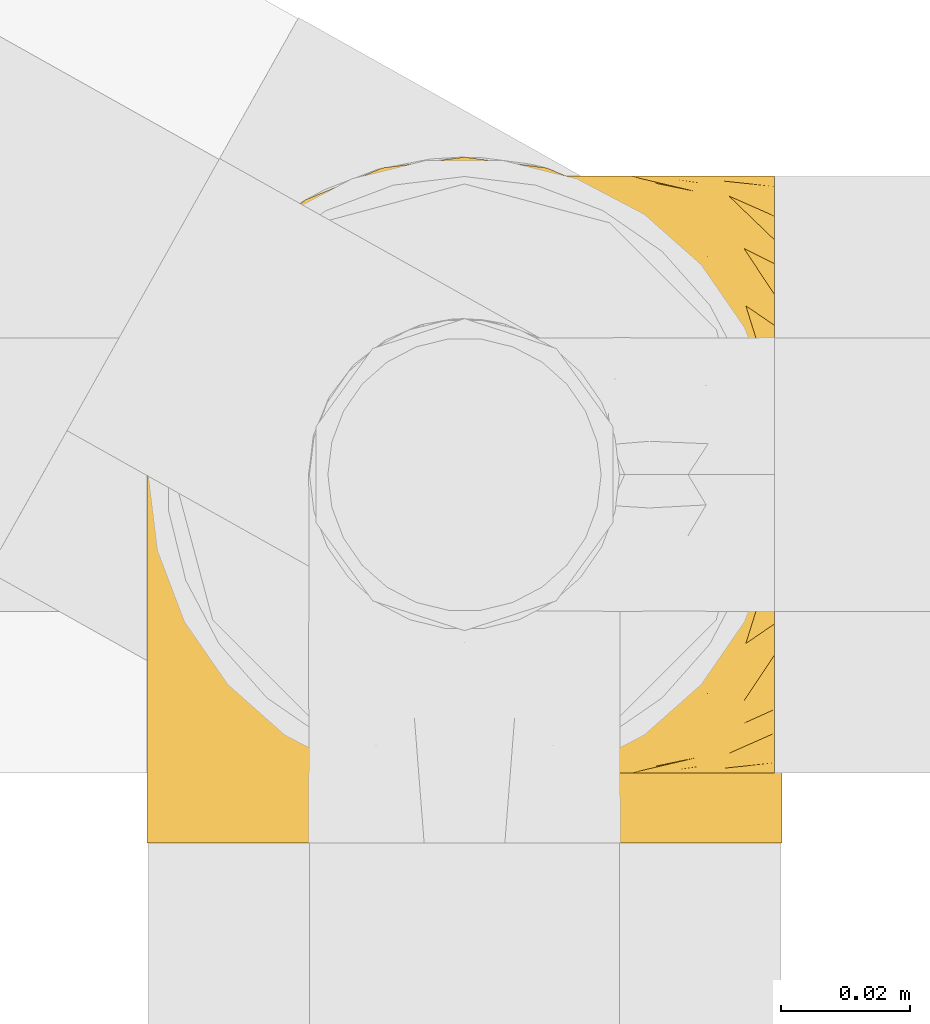
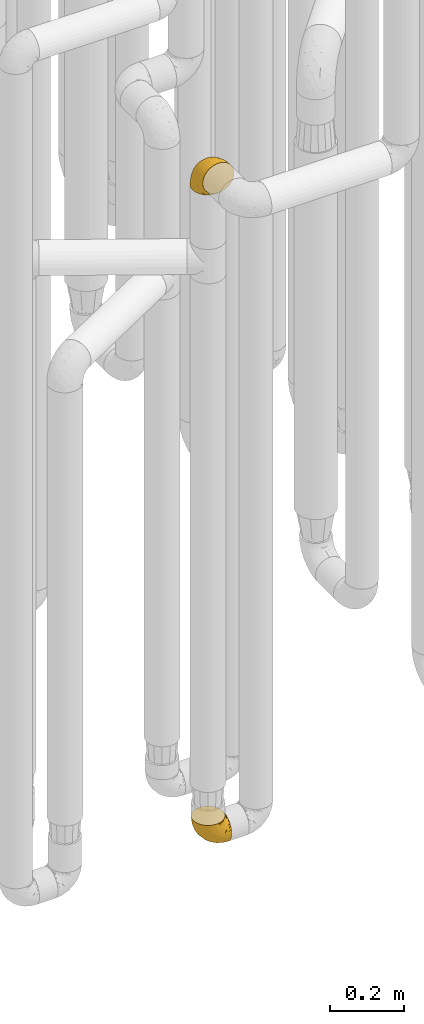
# One storey, part 152 of 827: 2 coverings.
"""IFC2X3 building model written with IfcOpenShell, lengths in millimetres."""

from ifc_helpers import new_model, entity, si_unit, converted_unit, derived_unit, direction, frame, origin, place, context, subcontext, project, spatial, faceted_brep, element, save


model = new_model("IFC2X3")

# Units and contexts
model_context = context("Model", 3, precision=0.01, world=origin(), true_north=direction((6.12303176911189e-17, 1.0)))
body_context = subcontext(model_context, "Body", "Model", "MODEL_VIEW")
ifc_project = project(units=[si_unit("LENGTHUNIT", "METRE", prefix="MILLI"), si_unit("AREAUNIT", "SQUARE_METRE"), si_unit("VOLUMEUNIT", "CUBIC_METRE"), converted_unit("PLANEANGLEUNIT", "DEGREE", entity("IfcRatioMeasure", 0.0174532925199433), si_unit("PLANEANGLEUNIT", "RADIAN"), dimensions=[0, 0, 0, 0, 0, 0, 0]), si_unit("MASSUNIT", "GRAM", prefix="KILO"), derived_unit("MASSDENSITYUNIT", [(si_unit("MASSUNIT", "GRAM", prefix="KILO"), 1), (si_unit("LENGTHUNIT", "METRE"), -3)]), derived_unit("MOMENTOFINERTIAUNIT", [(si_unit("LENGTHUNIT", "METRE"), 4)]), si_unit("TIMEUNIT", "SECOND"), si_unit("FREQUENCYUNIT", "HERTZ"), si_unit("THERMODYNAMICTEMPERATUREUNIT", "DEGREE_CELSIUS"), derived_unit("THERMALTRANSMITTANCEUNIT", [(si_unit("MASSUNIT", "GRAM", prefix="KILO"), 1), (si_unit("THERMODYNAMICTEMPERATUREUNIT", "KELVIN"), -1), (si_unit("TIMEUNIT", "SECOND"), -3)]), derived_unit("VOLUMETRICFLOWRATEUNIT", [(si_unit("LENGTHUNIT", "METRE"), 3), (si_unit("TIMEUNIT", "SECOND"), -1)]), derived_unit("MASSFLOWRATEUNIT", [(si_unit("MASSUNIT", "GRAM", prefix="KILO"), 1), (si_unit("TIMEUNIT", "SECOND"), -1)]), derived_unit("ROTATIONALFREQUENCYUNIT", [(si_unit("TIMEUNIT", "SECOND"), -1)]), si_unit("ELECTRICCURRENTUNIT", "AMPERE"), si_unit("ELECTRICVOLTAGEUNIT", "VOLT"), si_unit("POWERUNIT", "WATT"), si_unit("FORCEUNIT", "NEWTON", prefix="KILO"), si_unit("ILLUMINANCEUNIT", "LUX"), si_unit("LUMINOUSFLUXUNIT", "LUMEN"), si_unit("LUMINOUSINTENSITYUNIT", "CANDELA"), derived_unit("USERDEFINED", [(si_unit("MASSUNIT", "GRAM", prefix="KILO"), -1), (si_unit("LENGTHUNIT", "METRE"), -2), (si_unit("TIMEUNIT", "SECOND"), 3), (si_unit("LUMINOUSFLUXUNIT", "LUMEN"), 1)]), derived_unit("LINEARVELOCITYUNIT", [(si_unit("LENGTHUNIT", "METRE"), 1), (si_unit("TIMEUNIT", "SECOND"), -1)]), si_unit("PRESSUREUNIT", "PASCAL"), derived_unit("USERDEFINED", [(si_unit("LENGTHUNIT", "METRE"), -2), (si_unit("MASSUNIT", "GRAM", prefix="KILO"), 1), (si_unit("TIMEUNIT", "SECOND"), -2)]), derived_unit("LINEARFORCEUNIT", [(si_unit("MASSUNIT", "GRAM", prefix="KILO"), 1), (si_unit("LENGTHUNIT", "METRE"), 1), (si_unit("TIMEUNIT", "SECOND"), -2), (si_unit("LENGTHUNIT", "METRE"), -1)]), derived_unit("PLANARFORCEUNIT", [(si_unit("MASSUNIT", "GRAM", prefix="KILO"), 1), (si_unit("LENGTHUNIT", "METRE"), 1), (si_unit("TIMEUNIT", "SECOND"), -2), (si_unit("LENGTHUNIT", "METRE"), -2)])], contexts=[model_context])

# Site, building, storey
site_placement = place(None, origin())
site = spatial("IfcSite", under=ifc_project, at=site_placement, CompositionType="ELEMENT")
building_placement = place(site_placement, origin())
building = spatial("IfcBuilding", under=site, at=building_placement, CompositionType="ELEMENT")
storey_placement = place(building_placement, frame((0.0, 0.0, 28200.0)))
storey = spatial("IfcBuildingStorey", under=building, at=storey_placement, Name="08", CompositionType="ELEMENT", Elevation=28200.0)

# Coverings
covering_1_placement = place(storey_placement, frame((35680.25, 10308.37, 352.2)))
element("IfcCovering", 1, at=covering_1_placement, inside=storey, Name=":ADSK_", ObjectType=":ADSK_", PredefinedType="INSULATION", context=body_context, shape_type="Brep", body=[
    faceted_brep([(18.98, 83.91, 95.8), (11.67, 76.59, 95.8), (6.17, 67.83, 95.8), (2.75, 58.07, 95.8), (1.6, 47.8, 95.8), (2.75, 37.51, 95.8), (6.17, 27.74, 95.8), (11.68, 18.98, 95.8), (19.0, 11.67, 95.8), (27.76, 6.17, 95.8), (37.52, 2.75, 95.8), (47.8, 1.6, 95.8), (51.94, 2.06, 95.8), (55.01, 2.41, 95.8), (58.08, 2.75, 95.8), (62.96, 4.46, 95.8), (67.85, 6.17, 95.8), (72.23, 8.93, 95.8), (76.61, 11.68, 95.8), (80.26, 15.34, 95.8), (83.92, 19.0, 95.8), (89.42, 27.76, 95.8), (91.13, 32.64, 95.8), (92.84, 37.52, 95.8), (94.0, 47.8, 95.8), (92.84, 58.08, 95.8), (91.13, 62.96, 95.8), (89.42, 67.85, 95.8), (83.91, 76.61, 95.8), (80.25, 80.26, 95.8), (76.59, 83.92, 95.8), (72.21, 86.67, 95.8), (67.83, 89.42, 95.8), (62.95, 91.13, 95.8), (58.07, 92.84, 95.8), (55.0, 93.18, 95.8), (51.94, 93.53, 95.8), (47.8, 94.0, 95.8), (37.51, 92.84, 95.8), (27.74, 89.42, 95.8), (95.8, 47.8, 94.0), (95.8, 35.84, 92.42), (95.8, 24.7, 87.81), (95.8, 19.91, 84.13), (95.8, 15.13, 80.46), (95.8, 11.46, 75.68), (95.8, 7.78, 70.9), (95.8, 5.48, 65.32), (95.8, 3.17, 59.75), (95.8, 2.69, 56.14), (95.8, 2.42, 54.06), (95.8, 2.14, 51.97), (95.8, 1.6, 47.8), (95.8, 3.17, 35.84), (95.8, 7.78, 24.7), (95.8, 15.13, 15.13), (95.8, 24.7, 7.78), (95.8, 35.84, 3.17), (95.8, 47.8, 1.6), (95.8, 59.75, 3.17), (95.8, 70.9, 7.78), (95.8, 80.46, 15.13), (95.8, 87.81, 24.7), (95.8, 92.42, 35.84), (95.8, 94.0, 47.8), (95.8, 93.45, 51.97), (95.8, 92.9, 56.14), (95.8, 92.42, 59.75), (95.8, 90.11, 65.32), (95.8, 87.81, 70.9), (95.8, 84.13, 75.68), (95.8, 80.46, 80.46), (95.8, 75.68, 84.13), (95.8, 70.9, 87.81), (95.8, 59.75, 92.42), (60.58, 71.98, 15.84), (74.11, 63.6, 6.99), (51.59, 59.72, 14.39), (66.69, 47.8, 6.21), (76.19, 55.16, 4.26), (84.43, 47.8, 3.39), (31.2, 63.76, 31.2), (42.88, 72.22, 26.47), (79.41, 74.18, 11.44), (60.7, 92.52, 47.66), (61.85, 94.0, 61.85), (65.75, 94.0, 59.25), (69.64, 94.0, 56.65), (73.53, 94.0, 54.05), (77.43, 94.0, 51.45), (74.59, 82.14, 19.8), (54.72, 80.34, 26.22), (64.18, 87.52, 31.58), (37.94, 79.59, 38.36), (25.89, 78.25, 51.54), (34.73, 85.01, 51.6), (42.89, 90.25, 55.97), (49.83, 93.2, 62.88), (48.58, 87.23, 41.35), (22.41, 85.55, 82.24), (78.69, 93.0, 40.88), (81.64, 89.31, 29.0), (6.22, 61.31, 74.06), (12.11, 56.86, 54.53), (14.81, 68.34, 57.98), (21.61, 65.71, 43.81), (22.41, 56.99, 38.22), (30.12, 72.15, 38.33), (10.01, 70.34, 74.76), (15.36, 78.36, 76.85), (3.39, 47.8, 84.43), (19.59, 47.8, 40.43), (30.01, 47.8, 30.01), (41.19, 93.06, 78.67), (48.54, 94.0, 92.06), (49.28, 94.0, 88.32), (49.82, 94.0, 85.6), (50.37, 94.0, 82.88), (50.91, 94.0, 80.15), (51.45, 94.0, 77.43), (31.61, 89.88, 76.36), (80.15, 94.0, 50.91), (82.88, 94.0, 50.37), (85.6, 94.0, 49.82), (88.32, 94.0, 49.28), (90.19, 94.0, 48.91), (92.06, 94.0, 48.54), (6.21, 47.8, 66.69), (54.05, 94.0, 73.53), (56.65, 94.0, 69.64), (59.25, 94.0, 65.75), (24.66, 83.7, 66.13), (40.43, 47.8, 19.59), (35.17, 55.9, 24.64), (12.9, 47.8, 53.56), (53.56, 47.8, 12.9), (85.34, 81.75, 82.81), (78.44, 86.43, 81.22), (84.37, 79.8, 86.57), (89.05, 69.84, 92.75), (82.76, 79.5, 89.68), (86.31, 88.08, 72.26), (83.73, 91.6, 64.73), (77.31, 92.93, 62.45), (87.78, 92.43, 60.63), (87.91, 93.24, 56.91), (81.29, 93.36, 58.14), (93.97, 57.25, 93.7), (70.76, 89.41, 83.4), (63.67, 92.89, 75.54), (62.62, 92.66, 79.46), (90.64, 79.58, 82.28), (84.08, 86.51, 76.25), (76.28, 86.29, 84.69), (77.45, 83.91, 90.18), (88.72, 90.94, 65.12), (71.28, 91.94, 71.71), (68.09, 91.98, 75.21), (91.07, 82.79, 78.6), (57.47, 93.16, 87.27), (70.34, 88.76, 87.92), (91.35, 73.94, 86.94), (62.99, 91.89, 86.1), (94.52, 47.8, 94.52), (76.47, 92.22, 66.23), (69.96, 88.56, 91.08), (89.86, 87.72, 71.77), (78.94, 88.33, 76.21), (73.51, 92.18, 68.59), (89.62, 71.78, 89.94), (84.09, 9.09, 76.25), (86.3, 7.51, 72.26), (91.06, 12.8, 78.6), (88.32, 1.6, 49.28), (92.06, 1.6, 48.54), (82.88, 1.6, 50.37), (85.6, 1.6, 49.82), (93.97, 38.35, 93.7), (89.63, 23.84, 89.95), (50.37, 1.6, 82.88), (49.82, 1.6, 85.6), (48.54, 1.6, 92.06), (49.28, 1.6, 88.32), (82.77, 16.1, 89.68), (70.36, 6.84, 87.92), (77.31, 2.66, 62.45), (76.47, 3.37, 66.24), (69.64, 1.6, 56.65), (65.75, 1.6, 59.25), (87.78, 3.16, 60.63), (87.91, 2.35, 56.91), (89.06, 25.77, 92.76), (90.65, 16.02, 82.28), (85.35, 13.85, 82.81), (73.53, 1.6, 54.05), (77.43, 1.6, 51.45), (81.29, 2.23, 58.14), (77.46, 11.69, 90.18), (76.29, 9.31, 84.7), (57.47, 2.43, 87.25), (63.71, 2.71, 75.58), (68.11, 3.61, 75.2), (70.77, 6.18, 83.39), (71.31, 3.66, 71.7), (78.46, 9.17, 81.22), (69.52, 6.77, 90.73), (62.64, 2.93, 79.47), (91.35, 21.66, 86.94), (59.25, 1.6, 65.75), (84.6, 16.09, 86.75), (62.98, 3.7, 86.08), (51.45, 1.6, 77.43), (54.05, 1.6, 73.53), (56.65, 1.6, 69.64), (83.73, 3.99, 64.73), (80.15, 1.6, 50.91), (88.72, 4.65, 65.12), (61.85, 1.6, 61.85), (73.56, 3.43, 68.62), (78.96, 7.27, 76.22), (91.36, 9.46, 74.03), (50.91, 1.6, 80.15), (62.87, 2.4, 49.81), (76.19, 40.43, 4.26), (73.57, 13.57, 19.95), (56.07, 11.3, 30.61), (49.77, 18.65, 25.71), (44.73, 27.26, 22.43), (60.58, 23.61, 15.85), (47.64, 3.07, 60.69), (78.32, 2.69, 40.49), (51.59, 35.87, 14.39), (74.11, 31.99, 6.99), (76.04, 6.71, 29.56), (79.41, 21.41, 11.45), (14.82, 27.24, 57.98), (6.22, 34.26, 74.06), (12.12, 38.73, 54.52), (23.51, 26.97, 43.47), (31.2, 31.83, 31.2), (34.96, 23.4, 33.27), (33.86, 6.91, 64.26), (38.94, 3.4, 74.29), (30.23, 5.84, 80.41), (35.17, 39.69, 24.64), (15.85, 17.6, 73.62), (22.59, 10.38, 78.98), (21.56, 20.6, 53.69), (55.94, 5.36, 42.86), (20.67, 35.73, 41.67), (9.19, 24.84, 79.66), (25.79, 13.87, 58.41), (41.16, 9.06, 47.11), (37.95, 15.99, 38.37)], [[[0, 1, 2, 3, 4, 5, 6, 7, 8, 9, 10, 11, 12, 13, 14, 15, 16, 17, 18, 19, 20, 21, 22, 23, 24, 25, 26, 27, 28, 29, 30, 31, 32, 33, 34, 35, 36, 37, 38, 39]], [[40, 41, 42, 43, 44, 45, 46, 47, 48, 49, 50, 51, 52, 53, 54, 55, 56, 57, 58, 59, 60, 61, 62, 63, 64, 65, 66, 67, 68, 69, 70, 71, 72, 73, 74]], [[75, 76, 77]], [[78, 79, 80]], [[77, 81, 82]], [[76, 75, 83]], [[84, 85, 86, 87, 88, 89]], [[90, 91, 92]], [[76, 60, 59]], [[93, 94, 95]], [[90, 62, 61]], [[83, 61, 60]], [[96, 97, 84]], [[98, 93, 95]], [[0, 39, 99]], [[100, 84, 89]], [[62, 101, 63]], [[2, 102, 3]], [[92, 84, 100]], [[103, 102, 104]], [[103, 105, 106]], [[93, 107, 94]], [[1, 108, 2]], [[92, 101, 90]], [[108, 1, 109]], [[102, 110, 3]], [[93, 82, 107]], [[102, 108, 104]], [[111, 106, 112]], [[109, 0, 99]], [[113, 37, 114, 115, 116, 117, 118, 119]], [[120, 38, 113]], [[100, 89, 121, 122, 123, 124, 125, 126, 64]], [[127, 102, 103]], [[97, 119, 128, 129, 130, 85]], [[99, 120, 131]], [[132, 133, 77]], [[59, 80, 79]], [[1, 0, 109]], [[98, 84, 92]], [[94, 109, 131]], [[120, 39, 38]], [[93, 91, 82]], [[104, 94, 105]], [[97, 113, 119]], [[95, 120, 96]], [[83, 90, 61]], [[91, 93, 98]], [[64, 63, 100]], [[100, 63, 101]], [[77, 76, 79]], [[133, 106, 81]], [[84, 97, 85]], [[113, 96, 120]], [[113, 97, 96]], [[37, 113, 38]], [[110, 102, 127]], [[110, 4, 3]], [[103, 111, 134, 127]], [[90, 75, 91]], [[82, 81, 107]], [[91, 75, 82]], [[77, 82, 75]], [[76, 83, 60]], [[90, 83, 75]], [[105, 107, 81]], [[94, 131, 95]], [[105, 94, 107]], [[109, 94, 104]], [[120, 95, 131]], [[98, 95, 96]], [[84, 98, 96]], [[98, 92, 91]], [[106, 105, 81]], [[103, 104, 105]], [[112, 106, 133]], [[103, 106, 111]], [[112, 133, 132]], [[81, 77, 133]], [[77, 78, 135, 132]], [[120, 99, 39]], [[109, 99, 131]], [[59, 58, 80]], [[59, 79, 76]], [[90, 101, 62]], [[100, 101, 92]], [[2, 108, 102]], [[109, 104, 108]], [[78, 77, 79]], [[136, 137, 138]], [[27, 139, 140]], [[141, 142, 143]], [[144, 145, 121]], [[146, 89, 88]], [[147, 139, 25]], [[148, 149, 150]], [[136, 151, 152]], [[147, 40, 74]], [[24, 147, 25]], [[140, 153, 154]], [[33, 116, 34]], [[73, 72, 151]], [[114, 37, 36, 35, 34, 116, 115]], [[146, 155, 144]], [[156, 85, 130]], [[157, 149, 148]], [[151, 158, 152]], [[117, 33, 159]], [[29, 154, 160]], [[161, 74, 73]], [[162, 128, 119]], [[66, 65, 64, 126, 125, 124, 123, 122, 67]], [[163, 147, 24]], [[27, 140, 28]], [[149, 129, 150]], [[139, 27, 26, 25]], [[68, 144, 69]], [[129, 128, 150]], [[164, 87, 86]], [[130, 129, 149]], [[122, 145, 67]], [[154, 153, 148]], [[162, 119, 159]], [[165, 30, 160]], [[150, 160, 148]], [[128, 162, 150]], [[30, 165, 31]], [[145, 144, 68]], [[89, 146, 144]], [[87, 164, 143]], [[166, 155, 142]], [[88, 87, 143]], [[162, 160, 150]], [[160, 30, 29]], [[154, 29, 28]], [[140, 154, 28]], [[160, 154, 148]], [[140, 137, 153]], [[157, 148, 153]], [[156, 130, 157]], [[153, 137, 157]], [[157, 137, 156]], [[167, 137, 136]], [[168, 85, 156]], [[152, 168, 167]], [[167, 168, 156]], [[164, 152, 141]], [[71, 158, 72]], [[152, 167, 136]], [[88, 142, 146]], [[144, 155, 69]], [[146, 142, 155]], [[70, 166, 71]], [[142, 141, 166]], [[70, 69, 155]], [[141, 158, 71]], [[161, 73, 151]], [[138, 137, 140]], [[161, 136, 169]], [[136, 161, 151]], [[74, 161, 169]], [[152, 158, 141]], [[151, 72, 158]], [[168, 152, 164]], [[137, 167, 156]], [[164, 86, 168]], [[85, 168, 86]], [[116, 33, 117]], [[130, 149, 157]], [[67, 145, 68]], [[121, 89, 144]], [[145, 122, 121]], [[40, 147, 163]], [[169, 147, 74]], [[159, 33, 32]], [[162, 159, 32]], [[159, 119, 118, 117]], [[139, 147, 169]], [[139, 169, 138]], [[162, 32, 31]], [[141, 143, 164]], [[88, 143, 142]], [[71, 166, 141]], [[155, 166, 70]], [[139, 138, 140]], [[169, 136, 138]], [[160, 162, 165]], [[162, 31, 165]], [[170, 171, 172]], [[173, 174, 52, 51, 50, 49, 48, 175, 176]], [[177, 178, 41]], [[179, 15, 180]], [[12, 11, 181, 182, 180, 14, 13]], [[183, 21, 20]], [[19, 18, 184]], [[185, 186, 187]], [[186, 188, 187]], [[43, 172, 44]], [[189, 190, 47]], [[23, 22, 21, 191]], [[170, 192, 193]], [[40, 163, 177]], [[194, 195, 196]], [[24, 23, 177]], [[197, 198, 183]], [[199, 15, 179]], [[47, 46, 189]], [[200, 201, 202]], [[201, 203, 204]], [[205, 206, 184]], [[207, 41, 178]], [[16, 15, 199]], [[14, 180, 15]], [[202, 201, 198]], [[208, 201, 200]], [[163, 24, 177]], [[48, 47, 190]], [[196, 195, 189]], [[197, 184, 202]], [[204, 193, 209]], [[210, 211, 212]], [[206, 212, 213]], [[205, 17, 210]], [[184, 206, 202]], [[210, 212, 206]], [[185, 194, 214]], [[189, 215, 190]], [[216, 45, 214]], [[186, 171, 170]], [[189, 216, 196]], [[197, 20, 19]], [[194, 185, 187]], [[197, 183, 20]], [[184, 197, 19]], [[197, 202, 198]], [[206, 200, 202]], [[204, 183, 198]], [[201, 208, 203]], [[203, 208, 217]], [[204, 198, 201]], [[217, 188, 218]], [[193, 219, 170]], [[171, 186, 185]], [[170, 218, 186]], [[170, 219, 218]], [[42, 207, 192]], [[171, 220, 172]], [[216, 189, 46]], [[214, 194, 196]], [[44, 220, 45]], [[214, 196, 216]], [[216, 46, 45]], [[214, 45, 220]], [[192, 43, 42]], [[204, 203, 219]], [[207, 193, 192]], [[209, 193, 178]], [[41, 207, 42]], [[193, 207, 178]], [[43, 192, 172]], [[170, 172, 192]], [[204, 219, 193]], [[219, 203, 218]], [[217, 218, 203]], [[188, 186, 218]], [[206, 213, 200]], [[208, 200, 213]], [[199, 210, 16]], [[215, 189, 195]], [[215, 175, 190]], [[175, 48, 190]], [[199, 179, 221, 211]], [[210, 199, 211]], [[23, 191, 177]], [[40, 177, 41]], [[178, 177, 191]], [[21, 183, 191]], [[209, 191, 183]], [[205, 18, 17]], [[17, 16, 210]], [[171, 185, 214]], [[172, 220, 44]], [[214, 220, 171]], [[191, 209, 178]], [[204, 209, 183]], [[206, 205, 210]], [[18, 205, 184]], [[222, 195, 194, 187, 188, 217]], [[57, 223, 80]], [[224, 225, 226]], [[226, 227, 228]], [[229, 217, 208, 213, 212, 211]], [[230, 52, 174, 173, 176, 175, 215, 195]], [[231, 232, 228]], [[231, 78, 223]], [[223, 57, 232]], [[224, 233, 225]], [[233, 54, 53]], [[234, 232, 56]], [[56, 55, 234]], [[234, 224, 228]], [[235, 236, 237]], [[224, 55, 54]], [[238, 239, 240]], [[52, 230, 53]], [[241, 242, 243]], [[227, 244, 231]], [[11, 10, 242]], [[236, 6, 5]], [[7, 245, 8]], [[8, 246, 9]], [[238, 247, 235]], [[222, 229, 248]], [[242, 211, 221, 179, 180, 182, 181, 11]], [[233, 53, 230]], [[111, 112, 249]], [[250, 6, 236]], [[246, 251, 241]], [[6, 250, 7]], [[127, 236, 110]], [[248, 229, 252]], [[246, 8, 245]], [[235, 245, 250]], [[236, 5, 110]], [[235, 249, 238]], [[237, 236, 127]], [[243, 9, 246]], [[252, 229, 241]], [[56, 232, 57]], [[222, 230, 195]], [[225, 248, 252]], [[248, 233, 230]], [[54, 233, 224]], [[231, 228, 227]], [[244, 132, 231]], [[248, 225, 233]], [[226, 225, 253]], [[235, 250, 236]], [[245, 7, 250]], [[251, 246, 245]], [[243, 246, 241]], [[247, 245, 235]], [[252, 251, 253]], [[229, 222, 217]], [[230, 222, 248]], [[5, 4, 110]], [[237, 127, 134, 111]], [[238, 249, 239]], [[224, 234, 55]], [[232, 234, 228]], [[242, 241, 229]], [[10, 9, 243]], [[211, 242, 229]], [[10, 243, 242]], [[80, 223, 78]], [[80, 58, 57]], [[231, 223, 232]], [[227, 240, 239]], [[224, 226, 228]], [[240, 226, 253]], [[227, 239, 244]], [[226, 240, 227]], [[251, 247, 253]], [[240, 253, 247]], [[249, 235, 237]], [[237, 111, 249]], [[112, 132, 244]], [[112, 244, 249]], [[78, 231, 132, 135]], [[249, 244, 239]], [[247, 238, 240]], [[245, 247, 251]], [[251, 252, 241]], [[225, 252, 253]]]),
])
covering_2_placement = place(storey_placement, frame((35677.3, 10297.57, 2541.4)))
element("IfcCovering", 2, at=covering_2_placement, inside=storey, Name=":ADSK_", ObjectType=":ADSK_", PredefinedType="INSULATION", context=body_context, shape_type="Brep", body=[
    faceted_brep([(99.9, 1.6, 58.6), (98.66, 1.6, 69.54), (95.02, 1.6, 79.93), (89.17, 1.6, 89.25), (81.38, 1.6, 97.03), (72.06, 1.6, 102.88), (61.68, 1.6, 106.51), (50.75, 1.6, 107.75), (39.8, 1.6, 106.51), (29.41, 1.6, 102.87), (20.09, 1.6, 97.02), (12.31, 1.6, 89.23), (6.46, 1.6, 79.91), (2.83, 1.6, 69.53), (1.6, 1.6, 58.6), (2.24, 1.6, 52.89), (2.83, 1.6, 47.65), (4.65, 1.6, 42.46), (6.47, 1.6, 37.26), (12.32, 1.6, 27.94), (20.11, 1.6, 20.16), (29.43, 1.6, 14.31), (39.81, 1.6, 10.68), (50.75, 1.6, 9.45), (61.69, 1.6, 10.68), (72.08, 1.6, 14.32), (81.4, 1.6, 20.17), (89.18, 1.6, 27.96), (95.03, 1.6, 37.28), (96.85, 1.6, 42.47), (98.66, 1.6, 47.66), (99.25, 1.6, 52.89), (99.57, 1.6, 55.75), (38.02, 11.12, 1.6), (26.17, 16.03, 1.6), (21.08, 19.94, 1.6), (15.99, 23.84, 1.6), (12.09, 28.93, 1.6), (8.18, 34.02, 1.6), (5.73, 39.95, 1.6), (3.27, 45.87, 1.6), (2.35, 52.86, 1.6), (1.97, 55.73, 1.6), (1.6, 58.6, 1.6), (3.27, 71.32, 1.6), (8.18, 83.17, 1.6), (15.99, 93.35, 1.6), (26.17, 101.16, 1.6), (38.02, 106.07, 1.6), (50.75, 107.75, 1.6), (63.47, 106.07, 1.6), (75.32, 101.16, 1.6), (85.5, 93.35, 1.6), (93.31, 83.17, 1.6), (98.22, 71.32, 1.6), (99.9, 58.6, 1.6), (99.14, 52.86, 1.6), (98.22, 45.87, 1.6), (95.77, 39.95, 1.6), (93.31, 34.02, 1.6), (89.4, 28.93, 1.6), (85.5, 23.84, 1.6), (80.41, 19.94, 1.6), (75.32, 16.03, 1.6), (63.47, 11.12, 1.6), (50.75, 9.45, 1.6), (59.31, 81.82, 69.96), (73.08, 84.02, 59.59), (63.72, 93.05, 51.96), (50.75, 102.55, 34.4), (58.64, 104.83, 23.37), (50.75, 105.83, 13.68), (76.74, 91.87, 41.52), (67.68, 101.74, 26.26), (78.92, 97.07, 20.18), (94.31, 38.45, 72.33), (98.76, 22.17, 65.88), (98.4, 42.04, 57.55), (94.57, 77.69, 23.76), (89.91, 75.76, 46.5), (96.32, 62.11, 46.57), (98.79, 66.08, 21.17), (99.9, 54.26, 23.41), (99.9, 55.35, 17.92), (99.9, 56.44, 12.43), (99.9, 56.98, 9.72), (99.9, 57.52, 7.01), (87.31, 87.84, 26.77), (95.61, 19.41, 76.59), (60.43, 48.89, 95.55), (65.24, 26.34, 102.57), (72.87, 44.55, 92.89), (99.9, 23.41, 54.26), (99.9, 28.03, 51.17), (99.9, 32.65, 48.08), (99.9, 37.28, 44.99), (99.9, 41.9, 41.9), (90.65, 20.6, 85.16), (63.14, 63.36, 85.97), (91.89, 62.21, 59.58), (75.25, 19.94, 99.5), (50.75, 13.68, 105.83), (82.18, 80.85, 53.59), (85.08, 66.53, 67.0), (76.93, 71.06, 71.56), (50.75, 63.99, 87.47), (50.75, 75.73, 75.73), (83.02, 26.77, 92.24), (99.9, 4.31, 58.06), (99.9, 7.01, 57.52), (99.9, 12.43, 56.44), (99.9, 17.92, 55.35), (87.13, 43.43, 81.33), (80.85, 56.23, 80.35), (99.17, 54.97, 39.44), (50.75, 34.4, 102.55), (99.9, 44.99, 37.28), (99.9, 48.08, 32.65), (99.9, 51.17, 28.03), (50.75, 87.47, 63.99), (67.61, 74.55, 74.55), (72.25, 60.86, 83.62), (50.75, 49.19, 95.01), (50.75, 95.01, 49.19), (98.69, 10.27, 46.96), (99.01, 48.79, 8.77), (98.79, 45.16, 18.28), (98.29, 44.99, 11.68), (68.51, 6.17, 11.79), (76.82, 7.65, 15.69), (98.54, 21.59, 42.49), (99.3, 19.96, 47.41), (83.57, 21.0, 7.94), (89.47, 27.2, 9.27), (75.76, 14.83, 7.98), (84.86, 19.7, 13.4), (75.89, 10.93, 13.04), (64.77, 9.63, 7.36), (90.83, 19.97, 23.46), (94.62, 21.13, 30.46), (90.37, 14.14, 26.54), (91.18, 30.2, 6.76), (88.65, 8.12, 26.46), (84.11, 9.93, 20.77), (91.75, 24.62, 20.68), (96.86, 11.87, 40.26), (50.75, 7.15, 7.15), (58.97, 5.32, 9.28), (98.37, 26.68, 38.78), (83.91, 13.92, 18.27), (97.52, 30.67, 31.78), (95.55, 36.65, 12.75), (98.76, 42.89, 22.96), (95.26, 34.04, 17.55), (98.04, 36.6, 27.63), (90.65, 26.41, 15.23), (93.51, 10.07, 33.25), (94.16, 15.83, 32.43), (99.1, 41.99, 27.9), (25.73, 14.83, 7.97), (10.84, 26.4, 15.22), (17.92, 21.01, 7.93), (16.64, 19.71, 13.38), (30.44, 5.72, 13.12), (2.95, 21.6, 42.49), (2.19, 19.96, 47.4), (1.6, 28.03, 51.17), (4.63, 11.87, 40.24), (17.39, 9.93, 20.76), (1.6, 56.44, 12.43), (1.6, 57.52, 7.01), (1.6, 58.06, 4.31), (12.86, 8.13, 26.44), (11.13, 14.15, 26.52), (3.2, 44.99, 11.68), (5.94, 36.65, 12.75), (12.02, 27.21, 9.27), (6.23, 34.04, 17.55), (10.31, 30.2, 6.76), (8.0, 10.06, 33.21), (7.34, 15.83, 32.41), (2.48, 48.79, 8.77), (2.73, 42.89, 22.96), (2.64, 45.38, 18.48), (1.6, 12.43, 56.44), (2.8, 10.28, 46.95), (36.71, 9.64, 7.36), (1.6, 55.35, 17.92), (1.6, 54.26, 23.41), (38.59, 6.05, 9.85), (1.6, 7.01, 57.52), (1.6, 9.72, 56.98), (1.6, 32.65, 48.08), (3.12, 26.68, 38.78), (17.59, 13.92, 18.25), (1.6, 37.28, 44.99), (3.98, 30.66, 31.74), (6.87, 21.14, 30.45), (3.45, 36.59, 27.63), (9.76, 24.6, 20.65), (1.6, 17.92, 55.35), (1.6, 23.41, 54.26), (25.62, 10.93, 13.03), (10.67, 19.97, 23.44), (2.39, 41.99, 27.9), (1.6, 48.08, 32.65), (1.6, 51.17, 28.03), (1.6, 44.99, 37.28), (1.6, 41.9, 41.9), (2.4, 55.26, 39.74), (42.85, 104.83, 23.37), (14.18, 87.84, 26.77), (11.56, 75.91, 46.18), (19.27, 80.84, 53.54), (24.75, 91.87, 41.53), (28.37, 83.98, 59.61), (5.95, 19.16, 76.79), (2.79, 22.37, 66.11), (2.71, 66.08, 21.17), (37.78, 93.05, 51.96), (33.81, 101.74, 26.26), (22.57, 97.07, 20.18), (6.92, 77.69, 23.76), (28.61, 44.55, 92.88), (36.24, 26.34, 102.57), (41.05, 48.9, 95.54), (24.55, 70.99, 71.63), (33.88, 74.55, 74.55), (7.11, 37.8, 72.51), (42.18, 81.82, 69.96), (18.46, 26.77, 92.23), (10.84, 20.6, 85.15), (20.69, 56.15, 80.45), (29.27, 60.85, 83.65), (3.1, 42.06, 57.57), (9.18, 57.03, 63.68), (38.38, 63.4, 85.95), (26.23, 19.94, 99.49), (14.34, 43.59, 81.23), (5.46, 62.61, 47.07), (16.39, 66.52, 66.99)], [[[0, 1, 2, 3, 4, 5, 6, 7, 8, 9, 10, 11, 12, 13, 14, 15, 16, 17, 18, 19, 20, 21, 22, 23, 24, 25, 26, 27, 28, 29, 30, 31, 32]], [[33, 34, 35, 36, 37, 38, 39, 40, 41, 42, 43, 44, 45, 46, 47, 48, 49, 50, 51, 52, 53, 54, 55, 56, 57, 58, 59, 60, 61, 62, 63, 64, 65]], [[66, 67, 68]], [[69, 70, 71]], [[68, 72, 73]], [[73, 72, 74]], [[75, 76, 77]], [[78, 79, 80]], [[51, 50, 73]], [[81, 82, 83, 84, 85, 86, 55]], [[52, 87, 53]], [[74, 52, 51]], [[2, 1, 88]], [[89, 90, 91]], [[77, 92, 93, 94, 95, 96]], [[55, 54, 81]], [[78, 53, 87]], [[5, 90, 6]], [[88, 76, 75]], [[97, 3, 2]], [[89, 91, 98]], [[99, 80, 79]], [[90, 5, 100]], [[74, 87, 52]], [[100, 5, 4]], [[90, 101, 6]], [[79, 102, 103]], [[102, 67, 104]], [[105, 98, 106]], [[107, 4, 3]], [[76, 0, 108, 109, 110, 111, 92]], [[107, 112, 113]], [[114, 77, 96]], [[89, 115, 90]], [[114, 96, 116, 117, 118, 82]], [[75, 97, 88]], [[119, 66, 68]], [[50, 71, 70]], [[100, 91, 90]], [[99, 77, 80]], [[102, 104, 103]], [[97, 107, 3]], [[80, 81, 78]], [[107, 97, 112]], [[68, 73, 70]], [[66, 98, 120]], [[78, 81, 54]], [[114, 81, 80]], [[53, 78, 54]], [[78, 87, 79]], [[102, 87, 72]], [[79, 103, 99]], [[4, 107, 100]], [[91, 100, 107]], [[88, 97, 2]], [[112, 97, 75]], [[99, 112, 75]], [[103, 104, 113]], [[91, 121, 98]], [[89, 105, 122, 115]], [[101, 90, 115]], [[101, 7, 6]], [[88, 1, 76]], [[0, 76, 1]], [[92, 77, 76]], [[73, 74, 51]], [[87, 74, 72]], [[81, 114, 82]], [[77, 114, 80]], [[87, 102, 79]], [[67, 102, 72]], [[68, 67, 72]], [[67, 120, 104]], [[120, 121, 104]], [[104, 121, 113]], [[121, 120, 98]], [[91, 107, 113]], [[91, 113, 121]], [[103, 113, 112]], [[106, 98, 66]], [[105, 89, 98]], [[106, 66, 119]], [[67, 66, 120]], [[68, 69, 123, 119]], [[50, 49, 71]], [[50, 70, 73]], [[112, 99, 103]], [[77, 99, 75]], [[69, 68, 70]], [[29, 124, 110]], [[84, 83, 125]], [[126, 82, 118]], [[59, 58, 127]], [[25, 128, 129]], [[130, 93, 131]], [[132, 62, 133]], [[134, 135, 136]], [[137, 65, 64]], [[64, 134, 137]], [[138, 139, 140]], [[111, 110, 124, 92]], [[134, 136, 137]], [[134, 64, 63]], [[141, 61, 60]], [[125, 58, 57]], [[142, 143, 140]], [[142, 26, 143]], [[127, 83, 82]], [[28, 124, 29]], [[108, 0, 32, 31, 30, 110, 109]], [[30, 29, 110]], [[135, 144, 138]], [[28, 145, 124]], [[57, 56, 55, 86, 85, 84]], [[146, 147, 23]], [[24, 23, 147]], [[25, 143, 26]], [[95, 94, 148]], [[24, 128, 25]], [[149, 138, 143]], [[124, 145, 131]], [[127, 58, 125]], [[150, 148, 139]], [[127, 126, 151]], [[151, 59, 127]], [[152, 151, 126]], [[153, 154, 155]], [[153, 133, 141]], [[145, 28, 27]], [[142, 156, 27]], [[157, 148, 130]], [[61, 133, 62]], [[134, 132, 135]], [[147, 128, 24]], [[65, 137, 146]], [[146, 137, 147]], [[128, 137, 136]], [[137, 128, 147]], [[128, 136, 129]], [[149, 129, 136]], [[25, 129, 143]], [[158, 152, 117]], [[152, 118, 117]], [[153, 151, 152]], [[158, 116, 154]], [[144, 150, 138]], [[153, 152, 158]], [[133, 153, 155]], [[133, 155, 132]], [[141, 60, 151]], [[135, 132, 155]], [[134, 63, 132]], [[144, 135, 155]], [[135, 138, 149]], [[155, 154, 144]], [[150, 154, 96]], [[154, 150, 144]], [[148, 94, 130]], [[82, 126, 127]], [[118, 152, 126]], [[150, 96, 95]], [[139, 148, 157]], [[150, 95, 148]], [[93, 92, 131]], [[130, 145, 156]], [[130, 94, 93]], [[84, 125, 57]], [[127, 125, 83]], [[140, 139, 157]], [[150, 139, 138]], [[140, 157, 142]], [[138, 140, 143]], [[156, 142, 157]], [[27, 26, 142]], [[130, 156, 157]], [[145, 27, 156]], [[132, 63, 62]], [[124, 131, 92]], [[130, 131, 145]], [[129, 149, 143]], [[135, 149, 136]], [[153, 141, 151]], [[59, 151, 60]], [[133, 61, 141]], [[116, 96, 154]], [[153, 158, 154]], [[158, 117, 116]], [[34, 33, 159]], [[160, 161, 162]], [[22, 21, 163]], [[164, 165, 166]], [[19, 18, 167]], [[168, 21, 20]], [[42, 41, 40, 169, 170, 171, 43]], [[172, 173, 168]], [[174, 38, 175]], [[176, 177, 178]], [[179, 164, 180]], [[40, 181, 169]], [[182, 183, 175]], [[17, 184, 185]], [[65, 146, 186]], [[187, 174, 188]], [[23, 22, 189]], [[174, 39, 38]], [[15, 14, 190, 191, 184, 16]], [[181, 40, 39]], [[192, 193, 164]], [[194, 163, 168]], [[33, 186, 159]], [[180, 173, 172]], [[195, 196, 193]], [[18, 185, 167]], [[173, 180, 197]], [[198, 199, 196]], [[200, 201, 185, 184]], [[184, 17, 16]], [[18, 17, 185]], [[202, 159, 186]], [[194, 168, 203]], [[189, 163, 202]], [[204, 205, 182]], [[187, 181, 174]], [[160, 177, 176]], [[206, 183, 182]], [[206, 182, 205]], [[201, 165, 185]], [[165, 164, 167]], [[172, 179, 180]], [[202, 194, 162]], [[176, 161, 160]], [[65, 186, 33]], [[163, 189, 22]], [[175, 177, 182]], [[174, 183, 188]], [[177, 198, 204]], [[199, 160, 162]], [[198, 207, 204]], [[175, 38, 37]], [[198, 177, 160]], [[178, 177, 175]], [[176, 35, 161]], [[34, 159, 161]], [[162, 161, 159]], [[202, 162, 159]], [[199, 162, 203]], [[196, 199, 203]], [[198, 160, 199]], [[193, 197, 180]], [[208, 198, 196]], [[188, 183, 206]], [[175, 183, 174]], [[193, 192, 195]], [[195, 208, 196]], [[197, 196, 203]], [[180, 164, 193]], [[168, 163, 21]], [[166, 165, 201]], [[166, 192, 164]], [[189, 202, 186]], [[186, 146, 189]], [[23, 189, 146]], [[174, 181, 39]], [[169, 181, 187]], [[196, 197, 193]], [[173, 203, 168]], [[203, 173, 197]], [[172, 168, 20]], [[20, 19, 172]], [[179, 172, 19]], [[19, 167, 179]], [[164, 179, 167]], [[35, 176, 36]], [[35, 34, 161]], [[185, 165, 167]], [[162, 194, 203]], [[163, 194, 202]], [[176, 178, 36]], [[37, 36, 178]], [[175, 37, 178]], [[177, 204, 182]], [[207, 198, 208]], [[207, 205, 204]], [[209, 188, 206, 205, 207, 208]], [[48, 210, 71]], [[211, 212, 213]], [[214, 213, 215]], [[216, 217, 13]], [[218, 43, 171, 170, 169, 187, 188]], [[219, 220, 214]], [[47, 46, 221]], [[210, 48, 220]], [[211, 222, 212]], [[222, 45, 44]], [[221, 220, 47]], [[47, 220, 48]], [[221, 211, 214]], [[223, 224, 225]], [[211, 46, 45]], [[226, 227, 215]], [[43, 218, 44]], [[217, 216, 228]], [[219, 215, 229]], [[14, 13, 217]], [[224, 9, 8]], [[10, 230, 11]], [[11, 231, 12]], [[232, 223, 233]], [[234, 208, 195, 192, 166, 201]], [[235, 234, 228]], [[222, 44, 218]], [[106, 229, 236]], [[224, 237, 9]], [[231, 238, 228]], [[9, 237, 10]], [[115, 224, 101]], [[239, 234, 235]], [[231, 11, 230]], [[223, 230, 237]], [[224, 8, 101]], [[223, 236, 233]], [[225, 115, 122, 105]], [[216, 12, 231]], [[209, 234, 239]], [[210, 219, 69]], [[219, 214, 215]], [[229, 119, 219]], [[209, 218, 188]], [[239, 212, 222]], [[239, 222, 218]], [[45, 222, 211]], [[235, 212, 239]], [[213, 212, 240]], [[223, 237, 224]], [[230, 10, 237]], [[238, 231, 230]], [[216, 231, 228]], [[232, 230, 223]], [[235, 238, 240]], [[115, 225, 224]], [[233, 236, 227]], [[8, 7, 101]], [[234, 209, 208]], [[218, 209, 239]], [[217, 228, 234]], [[13, 12, 216]], [[234, 201, 217]], [[217, 201, 200, 184, 191, 190, 14]], [[211, 221, 46]], [[220, 221, 214]], [[71, 210, 69]], [[71, 49, 48]], [[219, 210, 220]], [[226, 215, 213]], [[211, 213, 214]], [[226, 213, 240]], [[215, 227, 229]], [[232, 240, 238]], [[233, 227, 226]], [[232, 233, 226]], [[236, 223, 225]], [[240, 232, 226]], [[232, 238, 230]], [[225, 105, 236]], [[236, 105, 106]], [[236, 229, 227]], [[123, 69, 219, 119]], [[106, 119, 229]], [[238, 235, 228]], [[212, 235, 240]]]),
])

save(model, "model.ifc")
